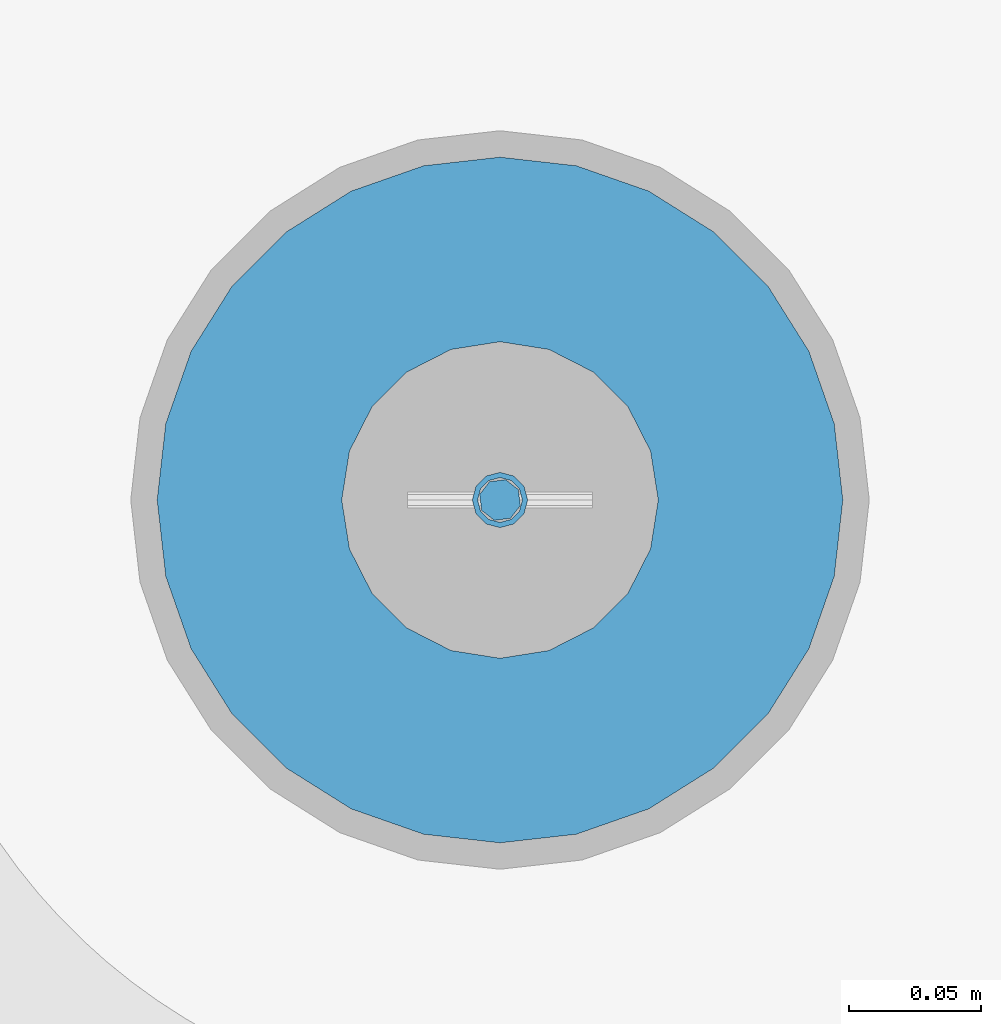
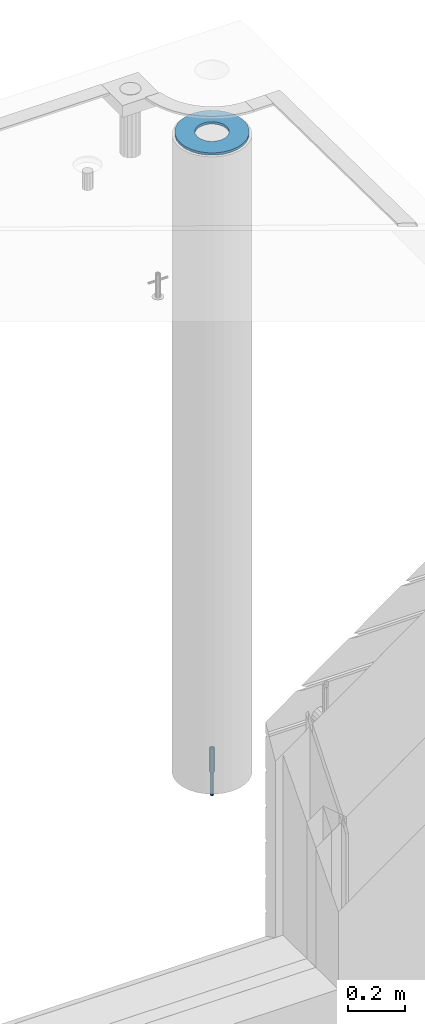
# One storey, part 38 of 349: 3 columns, 3 elements without a shape of their own.
"""IFC2X3 building model written with IfcOpenShell, lengths in millimetres."""

from ifc_helpers import new_model, si_unit, frame, origin_with_axes, place, context, subcontext, project, spatial, faceted_brep, material, type_object, element, aggregate, save


model = new_model("IFC2X3")

# Units and contexts
model_context = context("Model", 3, precision=1e-05, world=origin_with_axes())
body_context = subcontext(model_context, "Body", "Model", "MODEL_VIEW")
ifc_project = project(units=[si_unit("LENGTHUNIT", "METRE", prefix="MILLI"), si_unit("AREAUNIT", "SQUARE_METRE"), si_unit("VOLUMEUNIT", "CUBIC_METRE"), si_unit("MASSUNIT", "GRAM", prefix="KILO"), si_unit("TIMEUNIT", "SECOND"), si_unit("PLANEANGLEUNIT", "RADIAN"), si_unit("SOLIDANGLEUNIT", "STERADIAN"), si_unit("THERMODYNAMICTEMPERATUREUNIT", "DEGREE_CELSIUS"), si_unit("LUMINOUSINTENSITYUNIT", "LUMEN")], contexts=[model_context])

# Site, building, storey
site_placement = place(None, origin_with_axes())
site = spatial("IfcSite", under=ifc_project, at=site_placement, CompositionType="ELEMENT")
building_placement = place(site_placement, origin_with_axes())
building = spatial("IfcBuilding", under=site, at=building_placement, CompositionType="ELEMENT")
storey_placement = place(building_placement, origin_with_axes())
storey = spatial("IfcBuildingStorey", under=building, at=storey_placement, Name="4", CompositionType="ELEMENT", Elevation=0.0)

# Assemblies, columns
assembly_1_placement = place(storey_placement, origin_with_axes())
assembly_1 = element("IfcElementAssembly", 1, at=assembly_1_placement, inside=storey, AssemblyPlace="NOTDEFINED", PredefinedType="REINFORCEMENT_UNIT")
assembly_2_placement = place(assembly_1_placement, origin_with_axes())
assembly_2 = element("IfcElementAssembly", 2, at=assembly_2_placement, Name="Steel Assembly", AssemblyPlace="NOTDEFINED", PredefinedType="RIGID_FRAME")
ifc_material_1 = material(Name="STEEL/S235JR")
column_type_1 = type_object("IfcColumnType", Name="D16", PredefinedType="NOTDEFINED")
column_1_placement = place(assembly_2_placement, frame((35010.0004801435, 22669.9842012047, 90625.0), z_axis=(-0.261346946111888, -0.96524492941325, 0.0), x_axis=(0.0, 0.0, 1.0)))
column_1 = element("IfcColumn", 3, at=column_1_placement, type_object=column_type_1, material=ifc_material_1, Name="M16", ObjectType="D16", context=body_context, shape_type="Brep", body=[
    faceted_brep([(0.0, -8.0, 0.0), (0.0, -5.65685424949334, -5.65685424949334), (150.0, -5.65685424949697, -5.65685424949334), (150.0, -8.00000000000364, 0.0), (0.0, 0.0, -8.0), (150.0, -7.27595761418343e-12, -7.99999999999636), (0.0, 5.65685424949334, -5.65685424949334), (150.0, 5.6568542494897, -5.65685424949334), (0.0, 8.0, 0.0), (150.0, 8.0, -3.63797880709171e-12), (0.0, 5.65685424949334, 5.65685424949334), (150.0, 5.65685424949334, 5.65685424949697), (0.0, 0.0, 8.0), (150.0, -3.63797880709171e-12, 8.0), (0.0, -5.65685424949334, 5.65685424949334), (150.0, -5.65685424949334, 5.6568542494897)], [[[0, 1, 2, 3]], [[1, 4, 5, 2]], [[4, 6, 7, 5]], [[6, 8, 9, 7]], [[8, 10, 11, 9]], [[10, 12, 13, 11]], [[12, 14, 15, 13]], [[14, 0, 3, 15]], [[5, 7, 9, 11, 13, 15, 3, 2]], [[14, 12, 10, 8, 6, 4, 1, 0]]]),
])
aggregate(assembly_2, [column_1])
assembly_3_placement = place(assembly_1_placement, origin_with_axes())
assembly_3 = element("IfcElementAssembly", 4, at=assembly_3_placement, Name="Steel Assembly", AssemblyPlace="NOTDEFINED", PredefinedType="RIGID_FRAME")
ifc_material_2 = material(Name="STEEL/Steel_Undefined")
column_type_2 = type_object("IfcColumnType", PredefinedType="NOTDEFINED")
column_2_placement = place(assembly_3_placement, frame((35009.9987952044, 22669.984888838, 90725.0), z_axis=(0.0, 1.0, 0.0), x_axis=(0.0, 0.0, 1.0)))
column_2 = element("IfcColumn", 5, at=column_2_placement, type_object=column_type_2, material=ifc_material_2, context=body_context, shape_type="Brep", body=[
    faceted_brep([(0.0, -8.49999999999272, -1.45519152283669e-11), (0.0, -7.36121593215648, 4.24999999998545), (100.000000000262, -7.36121593215648, 4.24999999998545), (100.000000000262, -8.49999999999272, -1.45519152283669e-11), (0.0, -4.24999999998545, 7.36121593216376), (100.000000000262, -4.24999999998545, 7.36121593216376), (0.0, 1.45519152283669e-11, 8.49999999998545), (100.000000000262, 1.45519152283669e-11, 8.49999999998545), (0.0, 4.25000000001455, 7.36121593216376), (100.000000000262, 4.25000000001455, 7.36121593216376), (0.0, 7.36121593217104, 4.24999999998545), (100.000000000262, 7.36121593217104, 4.24999999998545), (0.0, 8.50000000000728, 0.0), (100.000000000262, 8.50000000000728, 0.0), (0.0, 7.36121593217104, -4.25000000001455), (100.000000000262, 7.36121593217104, -4.25000000001455), (0.0, 4.25000000000728, -7.36121593219286), (100.000000000262, 4.25000000000728, -7.36121593219286), (0.0, 7.27595761418343e-12, -8.5), (100.000000000262, 7.27595761418343e-12, -8.5), (0.0, -4.24999999999272, -7.36121593217831), (100.000000000262, -4.24999999999272, -7.36121593217831), (0.0, -7.36121593215648, -4.25), (100.000000000262, -7.36121593215648, -4.25), (0.0, -10.4999999999927, -1.45519152283669e-11), (0.0, -9.09326673972828, -5.25000000001455), (100.000000000262, -9.09326673972828, -5.25000000001455), (100.000000000262, -10.4999999999927, -1.45519152283669e-11), (0.0, -5.24999999998545, -9.09326673974283), (100.000000000262, -5.24999999998545, -9.09326673974283), (0.0, 7.27595761418343e-12, -10.5), (100.000000000262, 7.27595761418343e-12, -10.5), (0.0, 5.25000000001455, -9.09326673975738), (100.000000000262, 5.25000000001455, -9.09326673975738), (0.0, 9.09326673975011, -5.25000000001455), (100.000000000262, 9.09326673975011, -5.25000000001455), (0.0, 10.5000000000073, -1.45519152283669e-11), (100.000000000262, 10.5000000000073, -1.45519152283669e-11), (0.0, 9.09326673975011, 5.25), (100.000000000262, 9.09326673975011, 5.25), (0.0, 5.25000000000728, 9.09326673972828), (100.000000000262, 5.25000000000728, 9.09326673972828), (0.0, 1.45519152283669e-11, 10.4999999999854), (100.000000000262, 1.45519152283669e-11, 10.4999999999854), (0.0, -5.24999999999272, 9.09326673972828), (100.000000000262, -5.24999999999272, 9.09326673972828), (0.0, -9.09326673972828, 5.24999999998545), (100.000000000262, -9.09326673972828, 5.24999999998545)], [[[0, 1, 2, 3]], [[1, 4, 5, 2]], [[4, 6, 7, 5]], [[6, 8, 9, 7]], [[8, 10, 11, 9]], [[10, 12, 13, 11]], [[12, 14, 15, 13]], [[14, 16, 17, 15]], [[16, 18, 19, 17]], [[18, 20, 21, 19]], [[20, 22, 23, 21]], [[22, 0, 3, 23]], [[24, 25, 26, 27]], [[25, 28, 29, 26]], [[28, 30, 31, 29]], [[30, 32, 33, 31]], [[32, 34, 35, 33]], [[34, 36, 37, 35]], [[36, 38, 39, 37]], [[38, 40, 41, 39]], [[40, 42, 43, 41]], [[42, 44, 45, 43]], [[44, 46, 47, 45]], [[46, 24, 27, 47]], [[29, 31, 33, 35, 37, 39, 41, 43, 45, 47, 27, 26], [5, 7, 9, 11, 13, 15, 17, 19, 21, 23, 3, 2]], [[46, 44, 42, 40, 38, 36, 34, 32, 30, 28, 25, 24], [22, 20, 18, 16, 14, 12, 10, 8, 6, 4, 1, 0]]]),
])
aggregate(assembly_3, [column_2])
ifc_material_3 = material()
column_type_3 = type_object("IfcColumnType", Name="D260", PredefinedType="NOTDEFINED")
column_3_placement = place(assembly_1_placement, frame((35009.9987952044, 22669.984888838, 93435.0), z_axis=(-1.0, 3.00000001838171e-08, 0.0), x_axis=(0.0, 0.0, 1.0)))
column_3 = element("IfcColumn", 6, at=column_3_placement, type_object=column_type_3, material=ifc_material_3, Name="60", ObjectType="D260", context=body_context, shape_type="Brep", body=[
    faceted_brep([(10.0, -18.541019662498, -57.0633909777098), (0.0, -18.541019662498, -57.0633909777098), (0.0, -35.2671151375471, -48.5410196624944), (10.0, -35.2671151375471, -48.5410196624944), (0.0, -48.541019662498, -35.2671151375471), (10.0, -48.541019662498, -35.2671151375471), (0.0, -57.0633909777098, -18.5410196624944), (10.0, -57.0633909777098, -18.5410196624944), (0.0, -60.0, 0.0), (10.0, -60.0, 0.0), (0.0, -57.0633909777098, 18.5410196624944), (10.0, -57.0633909777098, 18.5410196624944), (0.0, -48.541019662498, 35.2671151375471), (10.0, -48.541019662498, 35.2671151375471), (0.0, -35.2671151375471, 48.5410196624944), (10.0, -35.2671151375471, 48.5410196624944), (0.0, -18.541019662498, 57.0633909777098), (10.0, -18.541019662498, 57.0633909777098), (0.0, 0.0, 60.0), (10.0, 0.0, 60.0), (0.0, 18.541019662498, 57.0633909777098), (10.0, 18.541019662498, 57.0633909777098), (0.0, 35.2671151375471, 48.5410196624944), (10.0, 35.2671151375471, 48.5410196624944), (0.0, 48.541019662498, 35.2671151375471), (10.0, 48.541019662498, 35.2671151375471), (0.0, 57.0633909777098, 18.5410196624944), (10.0, 57.0633909777098, 18.5410196624944), (0.0, 60.0, 0.0), (10.0, 60.0, 0.0), (0.0, 57.0633909777098, -18.5410196624944), (10.0, 57.0633909777098, -18.5410196624944), (0.0, 48.541019662498, -35.2671151375471), (10.0, 48.541019662498, -35.2671151375471), (0.0, 35.2671151375471, -48.5410196624944), (10.0, 35.2671151375471, -48.5410196624944), (0.0, 18.541019662498, -57.0633909777098), (10.0, 18.541019662498, -57.0633909777098), (0.0, 0.0, -60.0), (10.0, 0.0, -60.0), (0.0, -126.740628583637, -28.9277214143222), (0.0, -117.125952827315, -56.4048860852854), (10.0, -117.125952827315, -56.4048860852854), (10.0, -126.740628583637, -28.9277214143222), (0.0, -101.638092720845, -81.0536742416371), (10.0, -101.638092720845, -81.0536742416371), (0.0, -81.0536742416371, -101.638092720845), (10.0, -81.0536742416371, -101.638092720845), (0.0, -56.4048860852818, -117.125952827315), (10.0, -56.4048860852818, -117.125952827315), (0.0, -28.9277214143222, -126.740628583641), (10.0, -28.9277214143222, -126.740628583641), (0.0, 0.0, -130.0), (10.0, 0.0, -130.0), (0.0, 28.9277214143222, -126.740628583641), (10.0, 28.9277214143222, -126.740628583641), (0.0, 56.4048860852818, -117.125952827315), (10.0, 56.4048860852818, -117.125952827315), (0.0, 81.0536742416371, -101.638092720845), (10.0, 81.0536742416371, -101.638092720845), (0.0, 101.638092720845, -81.0536742416371), (10.0, 101.638092720845, -81.0536742416371), (0.0, 117.125952827315, -56.4048860852854), (10.0, 117.125952827315, -56.4048860852854), (0.0, 126.740628583637, -28.9277214143222), (10.0, 126.740628583637, -28.9277214143222), (0.0, 130.0, -1.81898940354586e-12), (10.0, 130.0, 0.0), (0.0, 126.740628583637, 28.9277214143222), (10.0, 126.740628583637, 28.9277214143222), (0.0, 117.125952827315, 56.4048860852854), (10.0, 117.125952827315, 56.4048860852854), (0.0, 101.638092720845, 81.0536742416371), (10.0, 101.638092720845, 81.0536742416371), (0.0, 81.0536742416371, 101.638092720845), (10.0, 81.0536742416371, 101.638092720845), (0.0, 56.4048860852818, 117.125952827315), (10.0, 56.4048860852818, 117.125952827315), (0.0, 28.9277214143222, 126.740628583641), (10.0, 28.9277214143222, 126.740628583641), (0.0, 0.0, 130.0), (10.0, 0.0, 130.0), (0.0, -28.9277214143222, 126.740628583641), (10.0, -28.9277214143222, 126.740628583641), (0.0, -56.4048860852818, 117.125952827315), (10.0, -56.4048860852818, 117.125952827315), (0.0, -81.0536742416371, 101.638092720845), (10.0, -81.0536742416371, 101.638092720845), (0.0, -101.638092720845, 81.0536742416371), (10.0, -101.638092720845, 81.0536742416371), (0.0, -117.125952827315, 56.4048860852854), (10.0, -117.125952827315, 56.4048860852854), (0.0, -126.740628583637, 28.9277214143222), (10.0, -126.740628583637, 28.9277214143222), (0.0, -130.0, -3.63797880709171e-12), (10.0, -130.0, 0.0)], [[[0, 1, 2, 3]], [[3, 2, 4, 5]], [[5, 4, 6, 7]], [[7, 6, 8, 9]], [[9, 8, 10, 11]], [[11, 10, 12, 13]], [[13, 12, 14, 15]], [[15, 14, 16, 17]], [[17, 16, 18, 19]], [[19, 18, 20, 21]], [[21, 20, 22, 23]], [[23, 22, 24, 25]], [[25, 24, 26, 27]], [[27, 26, 28, 29]], [[29, 28, 30, 31]], [[31, 30, 32, 33]], [[33, 32, 34, 35]], [[35, 34, 36, 37]], [[37, 36, 38, 39]], [[39, 38, 1, 0]], [[40, 41, 42, 43]], [[41, 44, 45, 42]], [[44, 46, 47, 45]], [[46, 48, 49, 47]], [[48, 50, 51, 49]], [[50, 52, 53, 51]], [[52, 54, 55, 53]], [[54, 56, 57, 55]], [[56, 58, 59, 57]], [[58, 60, 61, 59]], [[60, 62, 63, 61]], [[62, 64, 65, 63]], [[64, 66, 67, 65]], [[66, 68, 69, 67]], [[68, 70, 71, 69]], [[70, 72, 73, 71]], [[72, 74, 75, 73]], [[74, 76, 77, 75]], [[76, 78, 79, 77]], [[78, 80, 81, 79]], [[80, 82, 83, 81]], [[82, 84, 85, 83]], [[84, 86, 87, 85]], [[86, 88, 89, 87]], [[88, 90, 91, 89]], [[90, 92, 93, 91]], [[92, 94, 95, 93]], [[42, 45, 47, 49, 51, 53, 55, 57, 59, 61, 63, 65, 67, 69, 71, 73, 75, 77, 79, 81, 83, 85, 87, 89, 91, 93, 95, 43], [3, 5, 7, 9, 11, 13, 15, 17, 19, 21, 23, 25, 27, 29, 31, 33, 35, 37, 39, 0]], [[94, 40, 43, 95]], [[92, 90, 88, 86, 84, 82, 80, 78, 76, 74, 72, 70, 68, 66, 64, 62, 60, 58, 56, 54, 52, 50, 48, 46, 44, 41, 40, 94], [34, 32, 30, 28, 26, 24, 22, 20, 18, 16, 14, 12, 10, 8, 6, 4, 2, 1, 38, 36]]]),
])
aggregate(assembly_1, [assembly_3, assembly_2, column_3])

save(model, "model.ifc")
